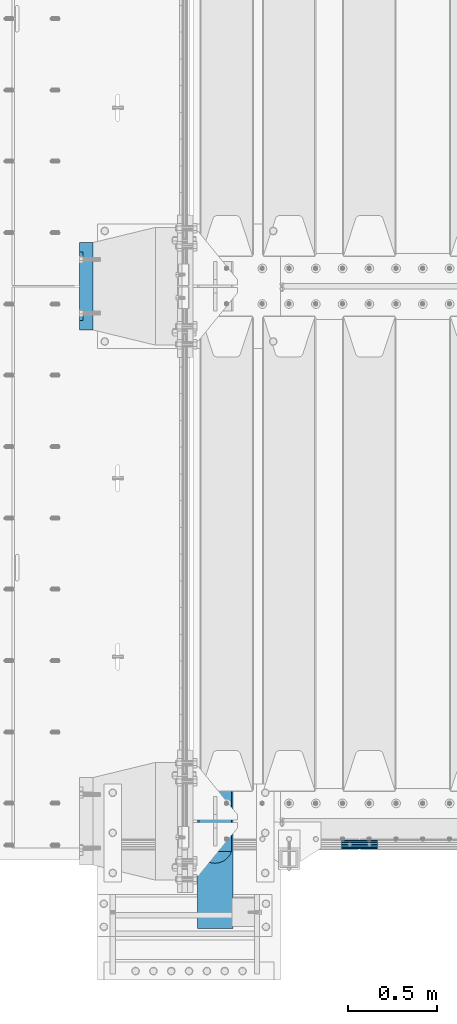
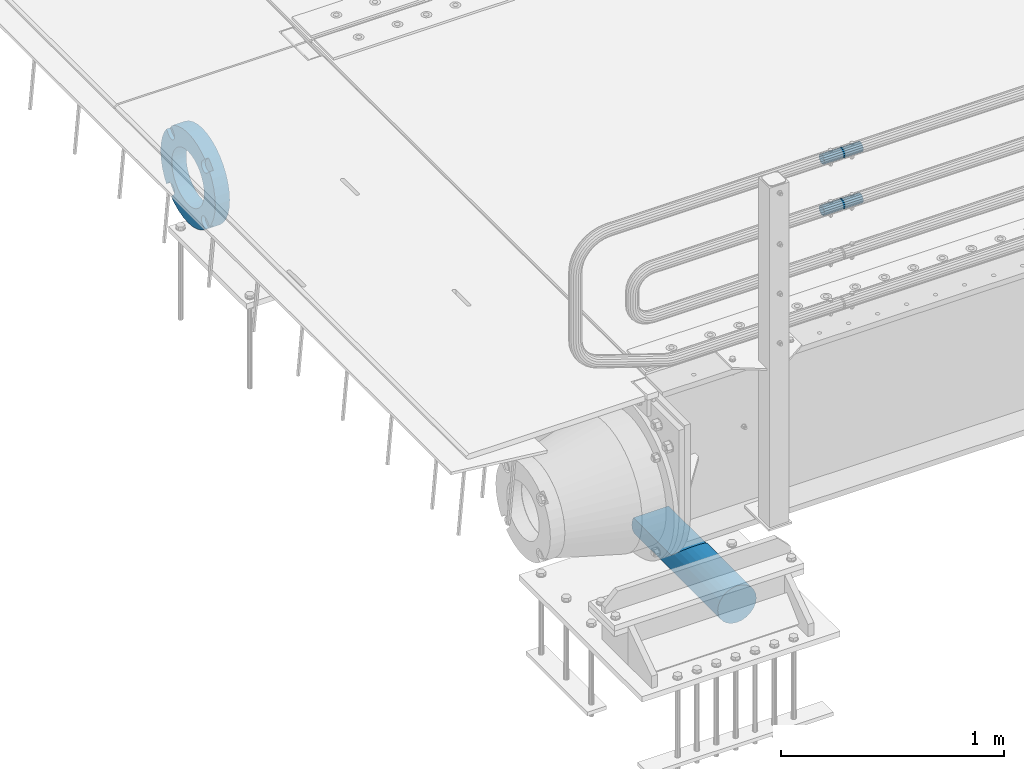
# One storey, part 122 of 219: 4 beams.
"""IFC2X3 building model written with IfcOpenShell, lengths in millimetres."""

from ifc_helpers import new_model, si_unit, frame, origin_with_axes, place, context, subcontext, project, spatial, faceted_brep, material, type_object, element, save


model = new_model("IFC2X3")

# Units and contexts
model_context = context("Model", 3, precision=1e-05, world=origin_with_axes())
body_context = subcontext(model_context, "Body", "Model", "MODEL_VIEW")
ifc_project = project(units=[si_unit("LENGTHUNIT", "METRE", prefix="MILLI"), si_unit("AREAUNIT", "SQUARE_METRE"), si_unit("VOLUMEUNIT", "CUBIC_METRE"), si_unit("MASSUNIT", "GRAM", prefix="KILO"), si_unit("TIMEUNIT", "SECOND"), si_unit("PLANEANGLEUNIT", "RADIAN"), si_unit("SOLIDANGLEUNIT", "STERADIAN"), si_unit("THERMODYNAMICTEMPERATUREUNIT", "DEGREE_CELSIUS"), si_unit("LUMINOUSINTENSITYUNIT", "LUMEN")], contexts=[model_context])

# Site, building, storey
site_placement = place(None, origin_with_axes())
site = spatial("IfcSite", under=ifc_project, at=site_placement, CompositionType="ELEMENT")
building_placement = place(site_placement, origin_with_axes())
building = spatial("IfcBuilding", under=site, at=building_placement, Name="Standard", CompositionType="ELEMENT")
storey_placement = place(building_placement, origin_with_axes())
storey = spatial("IfcBuildingStorey", under=building, at=storey_placement, Name="Undefined", CompositionType="ELEMENT", Elevation=0.0)

# Beams
ifc_material_1 = material(Name="STEEL/S355N")
beam_type_1 = type_object("IfcBeamType", Name="D200", PredefinedType="NOTDEFINED")
beam_1_placement = place(storey_placement, frame((135.0, 23400.0, -928.0), z_axis=(0.0, 0.0, 1.0), x_axis=(0.0, 1.0, 0.0)))
element("IfcBeam", 1, at=beam_1_placement, inside=storey, type_object=beam_type_1, material=ifc_material_1, ObjectType="D200", context=body_context, shape_type="Brep", body=[
    faceted_brep([(417.294117647056, 86.6025403784438, 50.0), (395.365164344956, 70.7106781186548, 70.7106781186548), (378.538486658115, 50.0, 86.6025403784439), (367.960794863509, 25.8819045102521, 96.5925826289068), (364.352941176468, 0.0, 100.0), (367.960794863509, -25.8819045102521, 96.5925826289068), (378.538486658115, -50.0, 86.6025403784439), (395.365164344956, -70.7106781186548, 70.7106781186548), (417.294117647056, -86.6025403784439, 50.0), (430.0, -91.573103126921, 38.0), (430.0, 91.573103126921, 38.0), (770.0, -91.573103126921, 38.0), (770.0, 91.573103126921, 38.0), (0.0, -96.5925826289068, 25.8819045102521), (0.0, -86.6025403784439, 50.0), (0.0, -70.7106781186548, 70.7106781186548), (0.0, -50.0, 86.6025403784439), (0.0, -25.8819045102521, 96.5925826289068), (0.0, 0.0, 100.0), (0.0, 25.8819045102521, 96.5925826289068), (0.0, 50.0, 86.6025403784439), (0.0, 70.7106781186548, 70.7106781186548), (0.0, 86.6025403784438, 50.0), (0.0, 96.5925826289068, 25.8819045102521), (0.0, 100.0, 0.0), (0.0, 96.5925826289068, -25.8819045102521), (0.0, 86.6025403784439, -50.0), (0.0, 70.7106781186548, -70.7106781186548), (0.0, 50.0, -86.6025403784438), (0.0, 25.8819045102522, -96.5925826289067), (0.0, 2.8421709430404e-14, -100.0), (0.0, -25.881904510252, -96.5925826289069), (0.0, -49.9999999999999, -86.6025403784439), (0.0, -70.7106781186548, -70.7106781186548), (0.0, -86.6025403784438, -50.0), (0.0, -96.5925826289068, -25.8819045102522), (0.0, -100.0, 0.0), (770.0, 96.5925826289068, 25.8819045102521), (770.0, 100.0, 0.0), (770.0, 96.5925826289068, -25.8819045102521), (770.0, 86.6025403784439, -50.0), (770.0, 70.7106781186548, -70.7106781186548), (770.0, 50.0000000000001, -86.6025403784438), (770.0, 25.8819045102522, -96.5925826289067), (770.0, 2.8421709430404e-14, -100.0), (770.0, -25.881904510252, -96.5925826289069), (770.0, -49.9999999999999, -86.6025403784439), (770.0, -70.7106781186547, -70.7106781186548), (770.0, -86.6025403784438, -50.0), (770.0, -96.5925826289068, -25.8819045102522), (770.0, -100.0, 0.0), (770.0, -96.5925826289068, 25.8819045102521)], [[[0, 1, 2, 3, 4, 5, 6, 7, 8, 9, 10]], [[10, 9, 11, 12]], [[13, 14, 15, 16, 17, 18, 19, 20, 21, 22, 23, 24, 25, 26, 27, 28, 29, 30, 31, 32, 33, 34, 35, 36]], [[24, 23, 37, 38]], [[25, 24, 38, 39]], [[26, 25, 39, 40]], [[27, 26, 40, 41]], [[28, 27, 41, 42]], [[29, 28, 42, 43]], [[30, 29, 43, 44]], [[31, 30, 44, 45]], [[32, 31, 45, 46]], [[33, 32, 46, 47]], [[34, 33, 47, 48]], [[35, 34, 48, 49]], [[36, 35, 49, 50]], [[13, 36, 50, 51]], [[14, 13, 51, 11, 9, 8]], [[15, 14, 8, 7]], [[16, 15, 7, 6]], [[17, 16, 6, 5]], [[18, 17, 5, 4]], [[19, 18, 4, 3]], [[20, 19, 3, 2]], [[21, 20, 2, 1]], [[22, 21, 1, 0]], [[37, 23, 22, 0, 10, 12]], [[51, 50, 49, 48, 47, 46, 45, 44, 43, 42, 41, 40, 39, 38, 37, 12, 11]]]),
])
ifc_material_2 = material()
beam_type_2 = type_object("IfcBeamType", PredefinedType="NOTDEFINED")
beam_2_placement = place(storey_placement, frame((844.997502999948, 23870.1500000004, 969.849999999747), z_axis=(0.0, 0.0, 1.0), x_axis=(1.0, 0.0, 0.0)))
element("IfcBeam", 2, at=beam_2_placement, inside=storey, type_object=beam_type_2, material=ifc_material_2, context=body_context, shape_type="Brep", body=[
    faceted_brep([(0.0, -21.9000000000015, 0.0), (0.0, -20.232961761998, 8.38076716879547), (200.0, -20.232961761998, 8.38076716879547), (200.0, -21.9000000000015, 0.0), (0.0, -15.4856385079838, 15.4856385079854), (200.0, -15.4856385079838, 15.4856385079854), (0.0, -8.38076716879732, 20.2329617619972), (200.0, -8.38076716879732, 20.2329617619972), (0.0, 0.0, 21.9), (200.0, 0.0, 21.9), (0.0, 8.38076716879732, 20.2329617619972), (200.0, 8.38076716879732, 20.2329617619972), (0.0, 15.4856385079838, 15.4856385079854), (200.0, 15.4856385079838, 15.4856385079854), (0.0, 20.232961761998, 8.38076716879547), (200.0, 20.232961761998, 8.38076716879547), (0.0, 21.9000000000015, 0.0), (200.0, 21.9000000000015, 0.0), (0.0, 20.232961761998, -8.38076716879547), (200.0, 20.232961761998, -8.38076716879547), (0.0, 15.4856385079838, -15.4856385079854), (200.0, 15.4856385079838, -15.4856385079854), (0.0, 8.38076716879732, -20.2329617619972), (200.0, 8.38076716879732, -20.2329617619972), (0.0, 0.0, -21.9), (200.0, 0.0, -21.9), (0.0, -8.38076716879732, -20.2329617619972), (200.0, -8.38076716879732, -20.2329617619972), (0.0, -15.4856385079838, -15.4856385079854), (200.0, -15.4856385079838, -15.4856385079854), (0.0, -20.232961761998, -8.38076716879547), (200.0, -20.232961761998, -8.38076716879547), (0.0, -25.5, 0.0), (0.0, -23.5589280790373, -9.7584275253098), (200.0, -23.5589280790373, -9.7584275253098), (200.0, -25.5, 0.0), (0.0, -18.0312229202536, -18.031222920257), (200.0, -18.0312229202536, -18.031222920257), (0.0, -9.75842752531025, -23.5589280790378), (200.0, -9.75842752531025, -23.5589280790378), (0.0, 0.0, -25.5), (200.0, 0.0, -25.5), (0.0, 9.75842752531025, -23.5589280790378), (200.0, 9.75842752531025, -23.5589280790378), (0.0, 18.0312229202536, -18.031222920257), (200.0, 18.0312229202536, -18.031222920257), (0.0, 23.5589280790373, -9.7584275253098), (200.0, 23.5589280790373, -9.7584275253098), (0.0, 25.5, 0.0), (200.0, 25.5, 0.0), (0.0, 23.5589280790373, 9.7584275253098), (200.0, 23.5589280790373, 9.7584275253098), (0.0, 18.0312229202536, 18.031222920257), (200.0, 18.0312229202536, 18.031222920257), (0.0, 9.75842752531025, 23.5589280790378), (200.0, 9.75842752531025, 23.5589280790378), (0.0, 0.0, 25.5), (200.0, 0.0, 25.5), (0.0, -9.75842752531025, 23.5589280790378), (200.0, -9.75842752531025, 23.5589280790378), (0.0, -18.0312229202536, 18.031222920257), (200.0, -18.0312229202536, 18.031222920257), (0.0, -23.5589280790373, 9.7584275253098), (200.0, -23.5589280790373, 9.7584275253098)], [[[0, 1, 2, 3]], [[1, 4, 5, 2]], [[4, 6, 7, 5]], [[6, 8, 9, 7]], [[8, 10, 11, 9]], [[10, 12, 13, 11]], [[12, 14, 15, 13]], [[14, 16, 17, 15]], [[16, 18, 19, 17]], [[18, 20, 21, 19]], [[20, 22, 23, 21]], [[22, 24, 25, 23]], [[24, 26, 27, 25]], [[26, 28, 29, 27]], [[28, 30, 31, 29]], [[30, 0, 3, 31]], [[32, 33, 34, 35]], [[33, 36, 37, 34]], [[36, 38, 39, 37]], [[38, 40, 41, 39]], [[40, 42, 43, 41]], [[42, 44, 45, 43]], [[44, 46, 47, 45]], [[46, 48, 49, 47]], [[48, 50, 51, 49]], [[50, 52, 53, 51]], [[52, 54, 55, 53]], [[54, 56, 57, 55]], [[56, 58, 59, 57]], [[58, 60, 61, 59]], [[60, 62, 63, 61]], [[62, 32, 35, 63]], [[37, 39, 41, 43, 45, 47, 49, 51, 53, 55, 57, 59, 61, 63, 35, 34], [5, 7, 9, 11, 13, 15, 17, 19, 21, 23, 25, 27, 29, 31, 3, 2]], [[62, 60, 58, 56, 54, 52, 50, 48, 46, 44, 42, 40, 38, 36, 33, 32], [30, 28, 26, 24, 22, 20, 18, 16, 14, 12, 10, 8, 6, 4, 1, 0]]]),
])
beam_3_placement = place(storey_placement, frame((844.997502999948, 23870.1500000004, 689.849999999747), z_axis=(0.0, 0.0, 1.0), x_axis=(1.0, 0.0, 0.0)))
element("IfcBeam", 3, at=beam_3_placement, inside=storey, type_object=beam_type_2, material=ifc_material_2, context=body_context, shape_type="Brep", body=[
    faceted_brep([(0.0, -21.9000000000015, 0.0), (0.0, -20.232961761998, 8.38076716879547), (200.0, -20.232961761998, 8.38076716879547), (200.0, -21.9000000000015, 0.0), (0.0, -15.4856385079838, 15.4856385079854), (200.0, -15.4856385079838, 15.4856385079854), (0.0, -8.38076716879732, 20.2329617619972), (200.0, -8.38076716879732, 20.2329617619972), (0.0, 0.0, 21.9), (200.0, 0.0, 21.9), (0.0, 8.38076716879732, 20.2329617619972), (200.0, 8.38076716879732, 20.2329617619972), (0.0, 15.4856385079838, 15.4856385079854), (200.0, 15.4856385079838, 15.4856385079854), (0.0, 20.232961761998, 8.38076716879547), (200.0, 20.232961761998, 8.38076716879547), (0.0, 21.9000000000015, 0.0), (200.0, 21.9000000000015, 0.0), (0.0, 20.232961761998, -8.38076716879547), (200.0, 20.232961761998, -8.38076716879547), (0.0, 15.4856385079838, -15.4856385079854), (200.0, 15.4856385079838, -15.4856385079854), (0.0, 8.38076716879732, -20.2329617619972), (200.0, 8.38076716879732, -20.2329617619972), (0.0, 0.0, -21.9), (200.0, 0.0, -21.9), (0.0, -8.38076716879732, -20.2329617619972), (200.0, -8.38076716879732, -20.2329617619972), (0.0, -15.4856385079838, -15.4856385079854), (200.0, -15.4856385079838, -15.4856385079854), (0.0, -20.232961761998, -8.38076716879547), (200.0, -20.232961761998, -8.38076716879547), (0.0, -25.5, 0.0), (0.0, -23.5589280790373, -9.7584275253098), (200.0, -23.5589280790373, -9.7584275253098), (200.0, -25.5, 0.0), (0.0, -18.0312229202536, -18.031222920257), (200.0, -18.0312229202536, -18.031222920257), (0.0, -9.75842752531025, -23.5589280790378), (200.0, -9.75842752531025, -23.5589280790378), (0.0, 0.0, -25.5), (200.0, 0.0, -25.5), (0.0, 9.75842752531025, -23.5589280790378), (200.0, 9.75842752531025, -23.5589280790378), (0.0, 18.0312229202536, -18.031222920257), (200.0, 18.0312229202536, -18.031222920257), (0.0, 23.5589280790373, -9.7584275253098), (200.0, 23.5589280790373, -9.7584275253098), (0.0, 25.5, 0.0), (200.0, 25.5, 0.0), (0.0, 23.5589280790373, 9.7584275253098), (200.0, 23.5589280790373, 9.7584275253098), (0.0, 18.0312229202536, 18.031222920257), (200.0, 18.0312229202536, 18.031222920257), (0.0, 9.75842752531025, 23.5589280790378), (200.0, 9.75842752531025, 23.5589280790378), (0.0, 0.0, 25.5), (200.0, 0.0, 25.5), (0.0, -9.75842752531025, 23.5589280790378), (200.0, -9.75842752531025, 23.5589280790378), (0.0, -18.0312229202536, 18.031222920257), (200.0, -18.0312229202536, 18.031222920257), (0.0, -23.5589280790373, 9.7584275253098), (200.0, -23.5589280790373, 9.7584275253098)], [[[0, 1, 2, 3]], [[1, 4, 5, 2]], [[4, 6, 7, 5]], [[6, 8, 9, 7]], [[8, 10, 11, 9]], [[10, 12, 13, 11]], [[12, 14, 15, 13]], [[14, 16, 17, 15]], [[16, 18, 19, 17]], [[18, 20, 21, 19]], [[20, 22, 23, 21]], [[22, 24, 25, 23]], [[24, 26, 27, 25]], [[26, 28, 29, 27]], [[28, 30, 31, 29]], [[30, 0, 3, 31]], [[32, 33, 34, 35]], [[33, 36, 37, 34]], [[36, 38, 39, 37]], [[38, 40, 41, 39]], [[40, 42, 43, 41]], [[42, 44, 45, 43]], [[44, 46, 47, 45]], [[46, 48, 49, 47]], [[48, 50, 51, 49]], [[50, 52, 53, 51]], [[52, 54, 55, 53]], [[54, 56, 57, 55]], [[56, 58, 59, 57]], [[58, 60, 61, 59]], [[60, 62, 63, 61]], [[62, 32, 35, 63]], [[37, 39, 41, 43, 45, 47, 49, 51, 53, 55, 57, 59, 61, 63, 35, 34], [5, 7, 9, 11, 13, 15, 17, 19, 21, 23, 25, 27, 29, 31, 3, 2]], [[62, 60, 58, 56, 54, 52, 50, 48, 46, 44, 42, 40, 38, 36, 33, 32], [30, 28, 26, 24, 22, 20, 18, 16, 14, 12, 10, 8, 6, 4, 1, 0]]]),
])
ifc_material_3 = material(Name="SCN-500-E2")
beam_type_3 = type_object("IfcBeamType", PredefinedType="NOTDEFINED")
beam_4_placement = place(storey_placement, frame((-550.0, 27000.0000014662, -515.0), z_axis=(0.0, 0.0, 1.0), x_axis=(-1.0, 0.0, 0.0)))
element("IfcBeam", 4, at=beam_4_placement, inside=storey, type_object=beam_type_3, material=ifc_material_3, context=body_context, shape_type="Brep", body=[
    faceted_brep([(75.0, 192.717024793295, -150.290616455866), (75.0000000000001, 171.473395903973, -129.046987566545), (55.0000000000002, 171.473395903973, -129.046987566545), (55.0000000000002, 192.717024793295, -150.290616455865), (75.0000000000001, 167.467485559311, -125.685629673395), (55.0000000000002, 167.467485559311, -125.685629673395), (75.0000000000001, 162.938740320955, -123.070957391003), (55.0000000000002, 162.938740320955, -123.070957391003), (75.0000000000001, 158.024763821777, -121.282416213472), (55.0000000000002, 158.024763821777, -121.282416213472), (75.0000000000001, 152.874864751095, -120.374350059435), (55.0000000000002, 152.874864751095, -120.374350059435), (75.0000000000001, 147.645520186205, -120.374350059479), (55.0000000000002, 147.645520186205, -120.374350059479), (75.0000000000001, 142.495621115537, -121.282416213595), (55.0000000000002, 142.495621115537, -121.282416213595), (75.0000000000001, 137.581644616374, -123.070957391204), (55.0000000000002, 137.581644616374, -123.070957391204), (75.0, 133.052899378039, -125.685629673665), (55.0000000000002, 133.052899378039, -125.685629673665), (75.0, 129.04698903278, -129.046987566545), (55.0000000000002, 129.04698903278, -129.046987566545), (75.0, 125.685631139982, -133.05289791162), (55.0000000000002, 125.685631139982, -133.05289791162), (75.0, 123.070958857592, -137.581643149926), (55.0000000000002, 123.070958857592, -137.581643149926), (75.0, 121.28241768005, -142.49561964906), (55.0000000000002, 121.28241768005, -142.49561964906), (75.0, 120.374351525992, -147.64551871968), (55.0000000000002, 120.374351525992, -147.64551871968), (75.0, 120.374351525999, -152.874863284513), (55.0000000000002, 120.374351525999, -152.874863284513), (75.0, 121.282417680093, -158.024762355132), (55.0000000000002, 121.282417680093, -158.024762355132), (75.0, 123.070958857665, -162.938738854251), (55.0000000000002, 123.070958857665, -162.938738854251), (75.0, 125.685631140077, -167.467484092545), (55.0000000000002, 125.685631140077, -167.467484092545), (75.0, 129.04698903278, -171.473394437738), (55.0000000000002, 129.04698903278, -171.473394437738), (55.0000000000002, 150.290618180639, -192.717023585594), (75.0, 150.290618180639, -192.717023585598), (55.0000000000002, 157.482964373201, -187.68088856415), (55.0000000000002, 187.680888564151, -157.482964373202), (75.0, -192.717023585596, 150.290618180639), (75.0, -171.4733929715, 129.046987566545), (55.0000000000002, -171.4733929715, 129.046987566545), (55.0000000000002, -192.717023585596, 150.290618180638), (75.0, -167.467482626838, 125.685629673395), (55.0000000000002, -167.467482626838, 125.685629673395), (75.0, -162.938737388482, 123.070957391003), (55.0000000000002, -162.938737388482, 123.070957391003), (75.0, -158.024760889304, 121.282416213472), (55.0000000000002, -158.024760889304, 121.282416213472), (75.0, -152.874861818622, 120.374350059435), (55.0000000000002, -152.874861818622, 120.374350059435), (75.0, -147.645517253732, 120.374350059479), (55.0000000000002, -147.645517253732, 120.374350059479), (75.0, -142.495618183064, 121.282416213595), (55.0000000000002, -142.495618183064, 121.282416213595), (75.0, -137.581641683901, 123.070957391204), (55.0000000000002, -137.581641683901, 123.070957391204), (75.0, -133.052896445566, 125.685629673665), (55.0000000000002, -133.052896445566, 125.685629673665), (75.0, -129.046986100308, 129.046987566545), (55.0000000000002, -129.046986100308, 129.046987566545), (75.0, -125.68562820751, 133.05289791162), (55.0000000000002, -125.68562820751, 133.05289791162), (75.0, -123.070955925119, 137.581643149926), (55.0000000000002, -123.070955925119, 137.581643149926), (75.0, -121.282414747577, 142.49561964906), (55.0000000000002, -121.282414747577, 142.49561964906), (75.0, -120.374348593519, 147.64551871968), (55.0000000000002, -120.374348593519, 147.64551871968), (75.0, -120.374348593527, 152.874863284513), (55.0000000000002, -120.374348593527, 152.874863284513), (75.0, -121.28241474762, 158.024762355132), (55.0000000000002, -121.28241474762, 158.024762355132), (75.0, -123.070955925192, 162.938738854251), (55.0000000000002, -123.070955925192, 162.938738854251), (75.0, -125.685628207604, 167.467484092545), (55.0000000000002, -125.685628207604, 167.467484092545), (75.0, -129.046986100308, 171.473394437738), (55.0000000000002, -129.046986100308, 171.473394437738), (55.0000000000002, -150.290616455859, 192.717024793291), (75.0, -150.290616455866, 192.717024793295), (75.0, 150.290618180639, 192.717023585596), (75.0000000000002, 129.04698903278, 171.473394437739), (55.0000000000002, 129.04698903278, 171.473394437739), (55.0000000000002, 150.290618180632, 192.717023585593), (75.0000000000002, 125.685631139633, 167.467484093078), (55.0000000000002, 125.685631139633, 167.467484093078), (75.0000000000002, 123.070958857235, 162.938738854723), (55.0000000000002, 123.070958857235, 162.938738854723), (75.0000000000002, 121.282417679708, 158.024762355545), (55.0000000000002, 121.282417679708, 158.024762355545), (75.0000000000002, 120.374351525672, 152.874863284862), (55.0000000000002, 120.374351525672, 152.874863284862), (75.0000000000002, 120.374351525716, 147.645518719972), (55.0000000000002, 120.374351525716, 147.645518719972), (75.0000000000002, 121.282417679831, 142.495619649306), (55.0000000000002, 121.282417679831, 142.495619649306), (75.0000000000002, 123.070958857439, 137.581643150138), (55.0000000000002, 123.070958857439, 137.581643150138), (75.0000000000002, 125.685631139902, 133.052897911806), (55.0000000000002, 125.685631139902, 133.052897911806), (75.0000000000002, 129.04698903278, 129.046987566546), (55.0000000000002, 129.04698903278, 129.046987566546), (75.0000000000002, 133.052899377857, 125.685629673749), (55.0000000000002, 133.052899377857, 125.685629673749), (75.0000000000002, 137.581644616163, 123.070957391354), (55.0000000000002, 137.581644616163, 123.070957391354), (75.0000000000002, 142.495621115297, 121.282416213815), (55.0000000000002, 142.495621115297, 121.282416213815), (75.0000000000002, 147.645520185913, 120.374350059761), (55.0000000000002, 147.645520185913, 120.374350059761), (75.0000000000002, 152.874864750745, 120.374350059768), (55.0000000000002, 152.874864750745, 120.374350059768), (75.0000000000002, 158.02476382137, 121.282416213859), (55.0000000000002, 158.02476382137, 121.282416213859), (75.0000000000002, 162.938740320489, 123.070957391429), (55.0000000000002, 162.938740320489, 123.070957391429), (75.0000000000002, 167.46748555878, 125.685629673842), (55.0000000000002, 167.46748555878, 125.685629673842), (75.0000000000002, 171.473395903973, 129.046987566546), (55.0000000000002, 171.473395903973, 129.046987566546), (55.0000000000002, 192.717024793295, 150.290616455867), (75.0, 192.717024793295, 150.290616455871), (0.0, 212.176223927185, -122.5), (0.0, 230.224692092546, -83.7949351147888), (75.0, 230.224692092546, -83.7949351147888), (75.0, 212.176223927185, -122.5), (0.0, 241.277899487992, -42.5438035283978), (75.0, 241.277899487992, -42.5438035283978), (0.0, 245.0, 0.0), (75.0, 245.0, 0.0), (0.0, 241.277899487992, 42.543803528398), (75.0, 241.277899487992, 42.543803528398), (0.0, 230.224692092546, 83.7949351147889), (75.0, 230.224692092546, 83.7949351147889), (0.0, 212.176223927185, 122.5), (75.0, 212.176223927185, 122.5), (0.0, 187.680888564151, 157.482964373202), (55.0000000000002, 187.680888564151, 157.482964373202), (0.0, 157.482964373201, 187.68088856415), (55.0000000000002, 157.482964373201, 187.68088856415), (0.0, 122.5, 212.176223927187), (75.0, 122.5, 212.176223927187), (0.0, 83.7949351147909, 230.224692092548), (75.0, 83.7949351147909, 230.224692092548), (0.0, 42.5438035283951, 241.277899487991), (75.0, 42.5438035283951, 241.277899487991), (0.0, 0.0, 245.0), (75.0, 0.0, 245.0), (0.0, -42.5438035283951, 241.277899487991), (75.0, -42.5438035283951, 241.277899487991), (0.0, -83.7949351147909, 230.224692092548), (75.0, -83.7949351147909, 230.224692092548), (0.0, -122.5, 212.176223927187), (75.0, -122.5, 212.176223927187), (0.0, -157.482964373201, 187.68088856415), (55.0000000000002, -157.482964373201, 187.68088856415), (0.0, -187.680888564151, 157.482964373202), (55.0000000000002, -187.680888564151, 157.482964373202), (0.0, -212.176223927185, 122.5), (75.0, -212.176223927185, 122.5), (0.0, -230.224692092546, 83.7949351147888), (75.0, -230.224692092546, 83.7949351147888), (0.0, -241.277899487992, 42.5438035283979), (75.0, -241.277899487992, 42.5438035283979), (0.0, -245.0, 0.0), (75.0, -245.0, 0.0), (0.0, -187.680888564151, -157.482964373202), (0.0, -157.482964373201, -187.68088856415), (55.0000000000002, -157.482964373201, -187.68088856415), (55.0000000000002, -187.680888564151, -157.482964373202), (0.0, 83.7949351147909, -230.224692092547), (0.0, 122.5, -212.176223927187), (75.0, 122.5, -212.176223927187), (75.0, 83.7949351147909, -230.224692092547), (0.0, 42.5438035283951, -241.277899487991), (75.0, 42.5438035283951, -241.277899487991), (0.0, 0.0, -245.0), (75.0, 0.0, -245.0), (0.0, -42.5438035283951, -241.277899487991), (75.0, -42.5438035283951, -241.277899487991), (0.0, -83.7949351147909, -230.224692092548), (75.0, -83.7949351147909, -230.224692092548), (0.0, -122.5, -212.176223927187), (75.0, -122.5, -212.176223927187), (75.0, -150.290616455866, -192.717024793295), (55.0000000000002, -150.290616455866, -192.717024793296), (55.0000000000002, -129.046986100308, -171.473394437739), (55.0000000000002, -125.68562820716, -167.467484093078), (55.0000000000002, -123.070955924763, -162.938738854723), (55.0000000000002, -121.282414747235, -158.024762355545), (55.0000000000002, -120.374348593199, -152.874863284861), (55.0000000000002, -120.374348593243, -147.645518719972), (55.0000000000002, -121.282414747358, -142.495619649306), (55.0000000000002, -123.070955924966, -137.581643150138), (55.0000000000002, -125.68562820743, -133.052897911806), (55.0000000000002, -129.046986100308, -129.046987566546), (55.0000000000002, -133.052896445384, -125.685629673749), (55.0000000000002, -137.58164168369, -123.070957391354), (55.0000000000002, -142.495618182824, -121.282416213815), (55.0000000000002, -147.645517253441, -120.374350059761), (55.0000000000002, -152.874861818273, -120.374350059768), (55.0000000000002, -158.024760888897, -121.282416213859), (55.0000000000002, -162.938737388016, -123.070957391429), (55.0000000000002, -167.467482626307, -125.685629673842), (55.0000000000002, -171.4733929715, -129.046987566546), (55.0000000000002, -192.717023585596, -150.290618180637), (75.0, -129.046986100308, -171.473394437739), (75.0, -125.68562820716, -167.467484093078), (75.0, -123.070955924763, -162.938738854723), (75.0, -121.282414747235, -158.024762355545), (75.0, -120.374348593199, -152.874863284861), (75.0, -120.374348593243, -147.645518719972), (75.0, -121.282414747358, -142.495619649306), (75.0, -123.070955924966, -137.581643150138), (75.0, -125.68562820743, -133.052897911806), (75.0, -129.046986100308, -129.046987566546), (75.0, -133.052896445384, -125.685629673749), (75.0, -137.58164168369, -123.070957391354), (75.0, -142.495618182824, -121.282416213815), (75.0, -147.645517253441, -120.374350059761), (75.0, -152.874861818273, -120.374350059768), (75.0, -158.024760888897, -121.282416213859), (75.0, -162.938737388016, -123.070957391429), (75.0, -167.467482626307, -125.685629673842), (75.0, -171.4733929715, -129.046987566546), (75.0, -192.717023585596, -150.29061818064), (75.0, -212.176223927185, -122.5), (0.0, -212.176223927185, -122.5), (0.0, -230.224692092546, -83.794935114789), (75.0, -230.224692092546, -83.794935114789), (0.0, -241.277899487992, -42.5438035283979), (75.0, -241.277899487992, -42.5438035283979), (0.0, 187.680888564151, -157.482964373202), (0.0, 157.482964373201, -187.68088856415), (0.0, -142.797124186771, -25.1789857617049), (0.0, -136.25543001396, -49.592920782222), (0.0, -125.573683548741, -72.5), (0.0, -111.076444252249, -93.2042034045483), (0.0, -93.2042034045517, -111.076444252252), (0.0, -72.5, -125.573683548744), (0.0, -49.5929207822192, -136.255430013957), (0.0, -25.1789857617041, -142.79712418677), (0.0, 0.0, -145.0), (0.0, 25.1789857617041, -142.79712418677), (0.0, 49.5929207822192, -136.255430013957), (0.0, 72.5, -125.573683548744), (0.0, 93.2042034045517, -111.076444252252), (0.0, 111.076444252249, -93.2042034045483), (0.0, 125.573683548741, -72.5), (0.0, 136.25543001396, -49.592920782222), (0.0, 142.797124186771, -25.178985761705), (0.0, 145.0, 0.0), (0.0, 142.797124186771, 25.1789857617048), (0.0, 136.25543001396, 49.5929207822219), (0.0, 125.573683548741, 72.4999999999999), (0.0, 111.076444252249, 93.2042034045482), (0.0, 93.2042034045517, 111.076444252252), (0.0, 72.5, 125.573683548744), (0.0, 49.5929207822192, 136.255430013957), (0.0, 25.1789857617041, 142.79712418677), (0.0, 0.0, 145.0), (0.0, -25.1789857617041, 142.79712418677), (0.0, -49.5929207822192, 136.255430013957), (0.0, -72.5, 125.573683548744), (0.0, -93.2042034045517, 111.076444252252), (0.0, -111.076444252249, 93.2042034045483), (0.0, -125.573683548741, 72.5000000000001), (0.0, -136.25543001396, 49.5929207822221), (0.0, -142.797124186771, 25.1789857617049), (0.0, -145.0, 0.0), (75.0, -145.0, 0.0), (75.0, -142.797124186771, -25.1789857617049), (75.0, -136.25543001396, -49.592920782222), (75.0, -125.573683548741, -72.5), (75.0, -111.076444252249, -93.2042034045483), (75.0, -93.2042034045517, -111.076444252252), (75.0, -72.5, -125.573683548744), (75.0, -49.5929207822192, -136.255430013957), (75.0, -25.1789857617041, -142.79712418677), (75.0, 0.0, -145.0), (75.0, 25.1789857617041, -142.79712418677), (75.0, 49.5929207822192, -136.255430013957), (75.0, 72.5, -125.573683548744), (75.0, 93.2042034045517, -111.076444252252), (75.0, 111.076444252249, -93.2042034045483), (75.0, 125.573683548741, -72.5), (75.0, 136.25543001396, -49.592920782222), (75.0, 142.797124186771, -25.178985761705), (75.0, 145.0, 0.0), (75.0, 142.797124186771, 25.1789857617048), (75.0, 136.25543001396, 49.5929207822219), (75.0, 125.573683548741, 72.4999999999999), (75.0, 111.076444252249, 93.2042034045482), (75.0, 93.2042034045517, 111.076444252252), (75.0, 72.5, 125.573683548744), (75.0, 49.5929207822192, 136.255430013957), (75.0, 25.1789857617041, 142.79712418677), (75.0, 0.0, 145.0), (75.0, -25.1789857617041, 142.79712418677), (75.0, -49.5929207822192, 136.255430013957), (75.0, -72.5, 125.573683548744), (75.0, -93.2042034045517, 111.076444252252), (75.0, -111.076444252249, 93.2042034045483), (75.0, -125.573683548741, 72.5000000000001), (75.0, -136.25543001396, 49.5929207822221), (75.0, -142.797124186771, 25.1789857617049)], [[[0, 1, 2, 3]], [[4, 5, 2, 1]], [[6, 7, 5, 4]], [[8, 9, 7, 6]], [[10, 11, 9, 8]], [[12, 13, 11, 10]], [[14, 15, 13, 12]], [[16, 17, 15, 14]], [[18, 19, 17, 16]], [[20, 21, 19, 18]], [[22, 23, 21, 20]], [[24, 25, 23, 22]], [[26, 27, 25, 24]], [[28, 29, 27, 26]], [[30, 31, 29, 28]], [[32, 33, 31, 30]], [[34, 35, 33, 32]], [[36, 37, 35, 34]], [[38, 39, 37, 36]], [[40, 39, 38, 41]], [[42, 43, 3, 2, 5, 7, 9, 11, 13, 15, 17, 19, 21, 23, 25, 27, 29, 31, 33, 35, 37, 39, 40]], [[44, 45, 46, 47]], [[48, 49, 46, 45]], [[50, 51, 49, 48]], [[52, 53, 51, 50]], [[54, 55, 53, 52]], [[56, 57, 55, 54]], [[58, 59, 57, 56]], [[60, 61, 59, 58]], [[62, 63, 61, 60]], [[64, 65, 63, 62]], [[66, 67, 65, 64]], [[68, 69, 67, 66]], [[70, 71, 69, 68]], [[72, 73, 71, 70]], [[74, 75, 73, 72]], [[76, 77, 75, 74]], [[78, 79, 77, 76]], [[80, 81, 79, 78]], [[82, 83, 81, 80]], [[84, 83, 82, 85]], [[86, 87, 88, 89]], [[90, 91, 88, 87]], [[92, 93, 91, 90]], [[94, 95, 93, 92]], [[96, 97, 95, 94]], [[98, 99, 97, 96]], [[100, 101, 99, 98]], [[102, 103, 101, 100]], [[104, 105, 103, 102]], [[106, 107, 105, 104]], [[108, 109, 107, 106]], [[110, 111, 109, 108]], [[112, 113, 111, 110]], [[114, 115, 113, 112]], [[116, 117, 115, 114]], [[118, 119, 117, 116]], [[120, 121, 119, 118]], [[122, 123, 121, 120]], [[124, 125, 123, 122]], [[126, 125, 124, 127]], [[128, 129, 130, 131]], [[129, 132, 133, 130]], [[132, 134, 135, 133]], [[134, 136, 137, 135]], [[136, 138, 139, 137]], [[138, 140, 141, 139]], [[127, 141, 140, 142, 143, 126]], [[142, 144, 145, 143]], [[89, 88, 91, 93, 95, 97, 99, 101, 103, 105, 107, 109, 111, 113, 115, 117, 119, 121, 123, 125, 126, 143, 145]], [[144, 146, 147, 86, 89, 145]], [[146, 148, 149, 147]], [[148, 150, 151, 149]], [[150, 152, 153, 151]], [[152, 154, 155, 153]], [[154, 156, 157, 155]], [[156, 158, 159, 157]], [[85, 159, 158, 160, 161, 84]], [[160, 162, 163, 161]], [[47, 46, 49, 51, 53, 55, 57, 59, 61, 63, 65, 67, 69, 71, 73, 75, 77, 79, 81, 83, 84, 161, 163]], [[162, 164, 165, 44, 47, 163]], [[164, 166, 167, 165]], [[166, 168, 169, 167]], [[168, 170, 171, 169]], [[172, 173, 174, 175]], [[176, 177, 178, 179]], [[180, 176, 179, 181]], [[182, 180, 181, 183]], [[184, 182, 183, 185]], [[186, 184, 185, 187]], [[188, 186, 187, 189]], [[173, 188, 189, 190, 191, 174]], [[175, 174, 191, 192, 193, 194, 195, 196, 197, 198, 199, 200, 201, 202, 203, 204, 205, 206, 207, 208, 209, 210, 211]], [[190, 212, 192, 191]], [[213, 193, 192, 212]], [[214, 194, 193, 213]], [[215, 195, 194, 214]], [[216, 196, 195, 215]], [[217, 197, 196, 216]], [[218, 198, 197, 217]], [[219, 199, 198, 218]], [[220, 200, 199, 219]], [[221, 201, 200, 220]], [[222, 202, 201, 221]], [[223, 203, 202, 222]], [[224, 204, 203, 223]], [[225, 205, 204, 224]], [[226, 206, 205, 225]], [[227, 207, 206, 226]], [[228, 208, 207, 227]], [[229, 209, 208, 228]], [[230, 210, 209, 229]], [[211, 210, 230, 231]], [[232, 233, 172, 175, 211, 231]], [[234, 233, 232, 235]], [[236, 234, 235, 237]], [[170, 236, 237, 171]], [[168, 166, 164, 162, 160, 158, 156, 154, 152, 150, 148, 146, 144, 142, 140, 138, 136, 134, 132, 129, 128, 238, 239, 177, 176, 180, 182, 184, 186, 188, 173, 172, 233, 234, 236, 170], [240, 241, 242, 243, 244, 245, 246, 247, 248, 249, 250, 251, 252, 253, 254, 255, 256, 257, 258, 259, 260, 261, 262, 263, 264, 265, 266, 267, 268, 269, 270, 271, 272, 273, 274, 275]], [[240, 275, 276, 277]], [[241, 240, 277, 278]], [[242, 241, 278, 279]], [[243, 242, 279, 280]], [[244, 243, 280, 281]], [[245, 244, 281, 282]], [[246, 245, 282, 283]], [[247, 246, 283, 284]], [[248, 247, 284, 285]], [[249, 248, 285, 286]], [[250, 249, 286, 287]], [[251, 250, 287, 288]], [[252, 251, 288, 289]], [[253, 252, 289, 290]], [[254, 253, 290, 291]], [[255, 254, 291, 292]], [[256, 255, 292, 293]], [[257, 256, 293, 294]], [[258, 257, 294, 295]], [[259, 258, 295, 296]], [[260, 259, 296, 297]], [[261, 260, 297, 298]], [[262, 261, 298, 299]], [[263, 262, 299, 300]], [[264, 263, 300, 301]], [[265, 264, 301, 302]], [[266, 265, 302, 303]], [[267, 266, 303, 304]], [[268, 267, 304, 305]], [[269, 268, 305, 306]], [[270, 269, 306, 307]], [[271, 270, 307, 308]], [[272, 271, 308, 309]], [[273, 272, 309, 310]], [[274, 273, 310, 311]], [[275, 274, 311, 276]], [[24, 22, 20, 18, 16, 14, 12, 10, 8, 6, 4, 1, 0, 131, 130, 133, 135, 137, 139, 141, 127, 124, 122, 120, 118, 116, 114, 112, 110, 108, 106, 104, 102, 100, 98, 96, 94, 92, 90, 87, 86, 147, 149, 151, 153, 155, 157, 159, 85, 82, 80, 78, 76, 74, 72, 70, 68, 66, 64, 62, 60, 58, 56, 54, 52, 50, 48, 45, 44, 165, 167, 169, 171, 237, 235, 232, 231, 230, 229, 228, 227, 226, 225, 224, 223, 222, 221, 220, 219, 218, 217, 216, 215, 214, 213, 212, 190, 189, 187, 185, 183, 181, 179, 178, 41, 38, 36, 34, 32, 30, 28, 26], [310, 309, 308, 307, 306, 305, 304, 303, 302, 301, 300, 299, 298, 297, 296, 295, 294, 293, 292, 291, 290, 289, 288, 287, 286, 285, 284, 283, 282, 281, 280, 279, 278, 277, 276, 311]], [[238, 128, 131, 0, 3, 43]], [[239, 238, 43, 42]], [[178, 177, 239, 42, 40, 41]]]),
])

save(model, "model.ifc")
